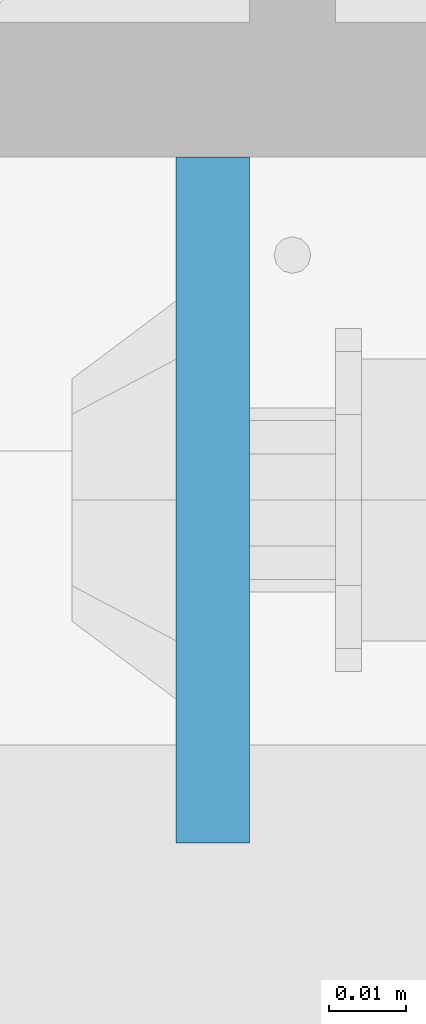
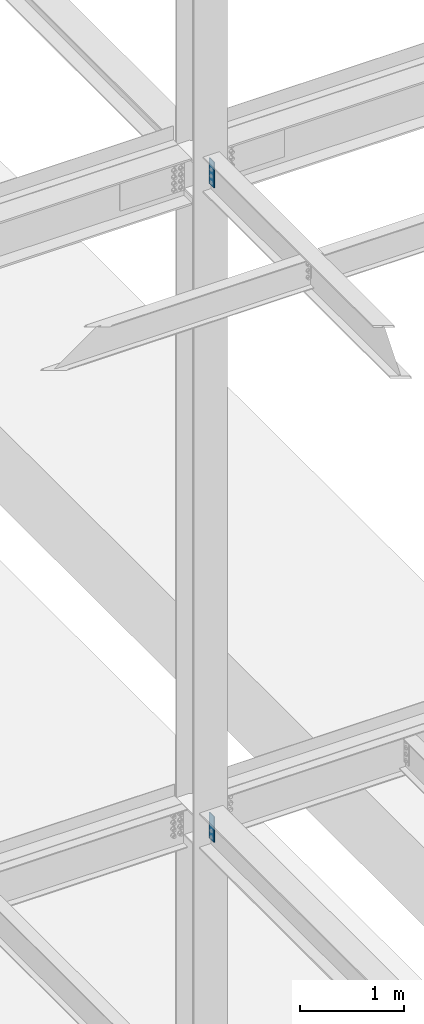
# One storey, part 1498 of 3843: 2 columns, 1 element without a shape of its own.
"""IFC2X3 building model written with IfcOpenShell, lengths in millimetres."""

from ifc_helpers import new_model, si_unit, frame, origin_with_axes, place, context, subcontext, project, spatial, faceted_brep, material, type_object, element, aggregate, save


model = new_model("IFC2X3")

# Units and contexts
model_context = context("Model", 3, precision=1e-05, world=origin_with_axes())
body_context = subcontext(model_context, "Body", "Model", "MODEL_VIEW")
ifc_project = project(units=[si_unit("LENGTHUNIT", "METRE", prefix="MILLI"), si_unit("AREAUNIT", "SQUARE_METRE"), si_unit("VOLUMEUNIT", "CUBIC_METRE"), si_unit("MASSUNIT", "GRAM", prefix="KILO"), si_unit("TIMEUNIT", "SECOND"), si_unit("PLANEANGLEUNIT", "RADIAN"), si_unit("SOLIDANGLEUNIT", "STERADIAN"), si_unit("THERMODYNAMICTEMPERATUREUNIT", "DEGREE_CELSIUS"), si_unit("LUMINOUSINTENSITYUNIT", "LUMEN")], contexts=[model_context])

# Site, building, storey
site_placement = place(None, origin_with_axes())
site = spatial("IfcSite", under=ifc_project, at=site_placement, CompositionType="ELEMENT")
building_placement = place(site_placement, origin_with_axes())
building = spatial("IfcBuilding", under=site, at=building_placement, Name="Undefined", CompositionType="ELEMENT")
storey_placement = place(building_placement, origin_with_axes())
storey = spatial("IfcBuildingStorey", under=building, at=storey_placement, Name="Undefined", CompositionType="ELEMENT", Elevation=0.0)

# Assembly, columns
assembly_placement = place(storey_placement, origin_with_axes())
assembly = element("IfcElementAssembly", 1, at=assembly_placement, inside=storey, Name="COLUMN", AssemblyPlace="NOTDEFINED", PredefinedType="RIGID_FRAME")
ifc_material = material(Name="STEEL/A572-50")
column_type = type_object("IfcColumnType", PredefinedType="NOTDEFINED")
column_1_placement = place(assembly_placement, frame((70246.08125, 25393.65, 42125.8999993376), z_axis=(0.0, 1.0, 0.0), x_axis=(0.0, 0.0, 1.0)))
column_1 = element("IfcColumn", 2, at=column_1_placement, type_object=column_type, material=ifc_material, Name="PLATE", context=body_context, shape_type="Brep", body=[
    faceted_brep([(0.0, 4.76249999999709, -44.4500000000007), (0.0, 4.76249999999709, 44.4500000000007), (304.799999999996, 4.76249999999709, 44.4500000000007), (304.799999999996, 4.76249999999709, -44.4500000000007), (0.0, -4.76249999999709, 44.4500000000007), (304.799999999996, -4.76249999999709, 44.4500000000007), (0.0, -4.76249999999709, -44.4500000000007), (304.799999999996, -4.76249999999709, -44.4500000000007)], [[[0, 1, 2, 3]], [[1, 4, 5, 2]], [[4, 6, 7, 5]], [[6, 0, 3, 7]], [[5, 7, 3, 2]], [[6, 4, 1, 0]]]),
])
column_2_placement = place(assembly_placement, frame((70246.08125, 25393.65, 34467.7999993376), z_axis=(0.0, 1.0, 0.0), x_axis=(0.0, 0.0, 1.0)))
column_2 = element("IfcColumn", 3, at=column_2_placement, type_object=column_type, material=ifc_material, Name="PLATE", context=body_context, shape_type="Brep", body=[
    faceted_brep([(0.0, 4.76249999999709, -44.4500000000007), (0.0, 4.76249999999709, 44.4500000000007), (304.799999999996, 4.76249999999709, 44.4500000000007), (304.799999999996, 4.76249999999709, -44.4500000000007), (0.0, -4.76249999999709, 44.4500000000007), (304.799999999996, -4.76249999999709, 44.4500000000007), (0.0, -4.76249999999709, -44.4500000000007), (304.799999999996, -4.76249999999709, -44.4500000000007)], [[[0, 1, 2, 3]], [[1, 4, 5, 2]], [[4, 6, 7, 5]], [[6, 0, 3, 7]], [[5, 7, 3, 2]], [[6, 4, 1, 0]]]),
])
aggregate(assembly, [column_1, column_2])

save(model, "model.ifc")
